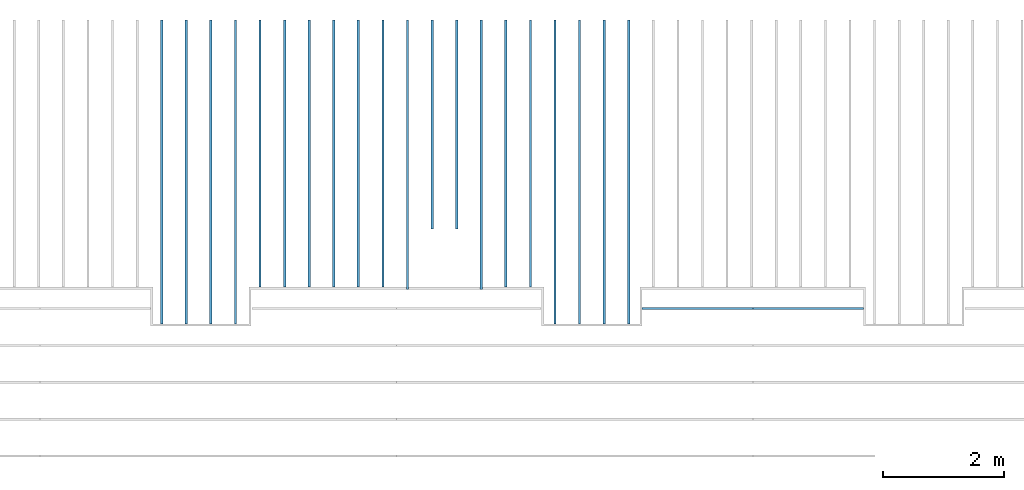
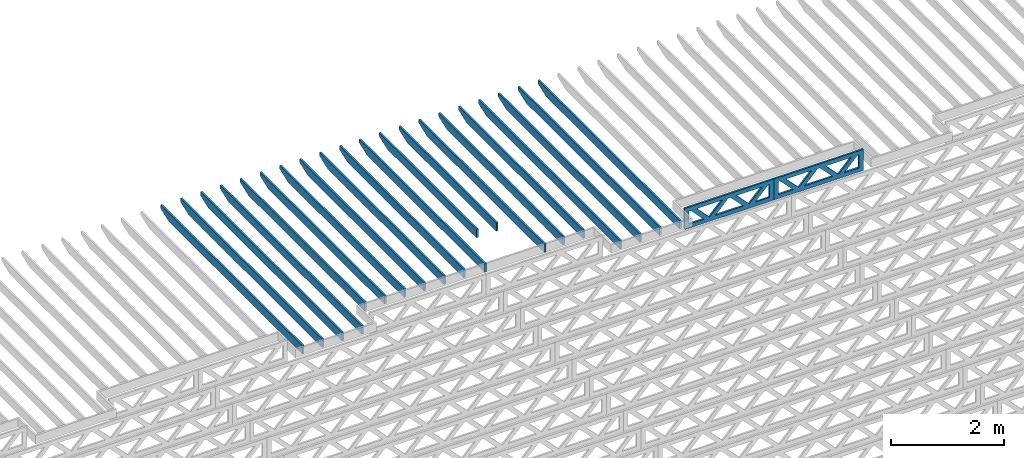
# One storey, part 9 of 17: 22 beams, 3 elements without a shape of their own.
"""IFC4 building model written with IfcOpenShell, lengths in feet."""

from ifc_helpers import new_model, entity, si_unit, converted_unit, derived_unit, direction, frame, frame_2d, origin, origin_2d_with_axis, place, context, subcontext, project, spatial, rectangle, extrude, clip, halfspace, source, transform, mapped, material, material_profile, profile_set, profile_usage, type_object, type_shapes, element, aggregate, save


model = new_model("IFC4")

# Units and contexts
model_context = context("Model", 3, precision=0.0001, world=origin(), true_north=direction((6.12303176911189e-17, 1.0)))
body_context = subcontext(model_context, "Body", "Model", "MODEL_VIEW")
ifc_project = project(units=[converted_unit("LENGTHUNIT", "FOOT", entity("IfcRatioMeasure", 0.3048), si_unit("LENGTHUNIT", "METRE"), dimensions=[1, 0, 0, 0, 0, 0, 0]), converted_unit("AREAUNIT", "SQUARE FOOT", entity("IfcRatioMeasure", 0.09290304), si_unit("AREAUNIT", "SQUARE_METRE"), dimensions=[2, 0, 0, 0, 0, 0, 0]), converted_unit("VOLUMEUNIT", "CUBIC FOOT", entity("IfcRatioMeasure", 0.028316846592), si_unit("VOLUMEUNIT", "CUBIC_METRE"), dimensions=[3, 0, 0, 0, 0, 0, 0]), converted_unit("PLANEANGLEUNIT", "DEGREE", entity("IfcRatioMeasure", 0.0174532925199433), si_unit("PLANEANGLEUNIT", "RADIAN"), dimensions=[0, 0, 0, 0, 0, 0, 0]), si_unit("MASSUNIT", "GRAM", prefix="KILO"), derived_unit("MASSDENSITYUNIT", [(si_unit("MASSUNIT", "GRAM", prefix="KILO"), 1), (si_unit("LENGTHUNIT", "METRE"), -3)]), derived_unit("MOMENTOFINERTIAUNIT", [(si_unit("LENGTHUNIT", "METRE"), 4)]), si_unit("TIMEUNIT", "SECOND"), si_unit("FREQUENCYUNIT", "HERTZ"), si_unit("THERMODYNAMICTEMPERATUREUNIT", "DEGREE_CELSIUS"), derived_unit("THERMALTRANSMITTANCEUNIT", [(si_unit("MASSUNIT", "GRAM", prefix="KILO"), 1), (si_unit("THERMODYNAMICTEMPERATUREUNIT", "KELVIN"), -1), (si_unit("TIMEUNIT", "SECOND"), -3)]), derived_unit("VOLUMETRICFLOWRATEUNIT", [(si_unit("LENGTHUNIT", "METRE"), 3), (si_unit("TIMEUNIT", "SECOND"), -1)]), si_unit("ELECTRICCURRENTUNIT", "AMPERE"), si_unit("ELECTRICVOLTAGEUNIT", "VOLT"), si_unit("POWERUNIT", "WATT"), si_unit("FORCEUNIT", "NEWTON"), si_unit("ILLUMINANCEUNIT", "LUX"), si_unit("LUMINOUSFLUXUNIT", "LUMEN"), si_unit("LUMINOUSINTENSITYUNIT", "CANDELA"), derived_unit("USERDEFINED", [(si_unit("MASSUNIT", "GRAM", prefix="KILO"), -1), (si_unit("LENGTHUNIT", "METRE"), -2), (si_unit("TIMEUNIT", "SECOND"), 3), (si_unit("LUMINOUSFLUXUNIT", "LUMEN"), 1)]), derived_unit("LINEARVELOCITYUNIT", [(si_unit("LENGTHUNIT", "METRE"), 1), (si_unit("TIMEUNIT", "SECOND"), -1)]), si_unit("PRESSUREUNIT", "PASCAL"), derived_unit("USERDEFINED", [(si_unit("LENGTHUNIT", "METRE"), -2), (si_unit("MASSUNIT", "GRAM", prefix="KILO"), 1), (si_unit("TIMEUNIT", "SECOND"), -2)]), derived_unit("LINEARFORCEUNIT", [(si_unit("MASSUNIT", "GRAM", prefix="KILO"), 1), (si_unit("LENGTHUNIT", "METRE"), 1), (si_unit("TIMEUNIT", "SECOND"), -2), (si_unit("LENGTHUNIT", "METRE"), -1)]), derived_unit("PLANARFORCEUNIT", [(si_unit("MASSUNIT", "GRAM", prefix="KILO"), 1), (si_unit("LENGTHUNIT", "METRE"), 1), (si_unit("TIMEUNIT", "SECOND"), -2), (si_unit("LENGTHUNIT", "METRE"), -2)])], contexts=[model_context])

# Site, building, storey
site_placement = place(None, origin())
site = spatial("IfcSite", under=ifc_project, at=site_placement, CompositionType="ELEMENT")
building_placement = place(site_placement, origin())
building = spatial("IfcBuilding", under=site, at=building_placement, CompositionType="ELEMENT")
storey_placement = place(building_placement, frame((0.0, 0.0, 30.4375000000082)))
storey = spatial("IfcBuildingStorey", under=building, at=storey_placement, Name="ROOF", CompositionType="ELEMENT", Elevation=30.4375000000082)

# Assembly, beam
assembly_1_placement = place(storey_placement, origin())
assembly_1 = element("IfcElementAssembly", 1, at=assembly_1_placement, inside=storey, Name="Structural Beam System:Structural Framing System", ObjectType="Structural Beam System:Structural Framing System", AssemblyPlace="NOTDEFINED", PredefinedType="BEAM_GRID")
ifc_material_1 = material(Name="WOOD TRUSS", Category="Materials")
ifc_material_profile_1 = material_profile(ifc_material_1, rectangle(XDim=1.73473973950632, YDim=0.125, at=origin_2d_with_axis()))
ifc_material_profile_2 = material_profile(ifc_material_1, rectangle(XDim=1.73473973950633, YDim=0.125, at=frame_2d((-1.11022302462516e-16, 0.0), x_axis=(1.0, 0.0))))
ifc_material_profile_3 = material_profile(ifc_material_1, rectangle(XDim=1.73473973950632, YDim=0.125, at=origin_2d_with_axis()))
ifc_material_profile_4 = material_profile(ifc_material_1, rectangle(XDim=1.73473973950633, YDim=0.125, at=origin_2d_with_axis()))
ifc_material_profile_5 = material_profile(ifc_material_1, rectangle(XDim=1.73473973950632, YDim=0.125, at=frame_2d((-5.55111512312578e-17, 0.0), x_axis=(1.0, 0.0))))
ifc_material_profile_6 = material_profile(ifc_material_1, rectangle(XDim=1.73473973950633, YDim=0.125, at=frame_2d((-2.77555756156289e-16, 0.0), x_axis=(1.0, 0.0))))
ifc_material_profile_7 = material_profile(ifc_material_1, rectangle(XDim=1.73473973950632, YDim=0.125, at=frame_2d((-4.9960036108132e-16, 0.0), x_axis=(1.0, 0.0))))
ifc_material_profile_8 = material_profile(ifc_material_1, rectangle(XDim=1.73473973950633, YDim=0.125, at=frame_2d((4.44089209850063e-16, 0.0), x_axis=(1.0, 0.0))))
ifc_material_profile_9 = material_profile(ifc_material_1, rectangle(XDim=1.73473973950632, YDim=0.125, at=origin_2d_with_axis()))
ifc_material_profile_10 = material_profile(ifc_material_1, rectangle(XDim=1.73473973950633, YDim=0.125, at=frame_2d((-4.9960036108132e-16, 0.0), x_axis=(1.0, 0.0))))
ifc_material_profile_11 = material_profile(ifc_material_1, rectangle(XDim=0.291666666666664, YDim=0.125, at=frame_2d((-2.77555756156289e-17, 0.0), x_axis=(1.0, 0.0))))
ifc_material_profile_12 = material_profile(ifc_material_1, rectangle(XDim=0.291666666666628, YDim=0.124999999999995, at=frame_2d((-5.55111512312578e-17, 0.0), x_axis=(1.0, 0.0))))
ifc_material_profile_13 = material_profile(ifc_material_1, rectangle(XDim=0.916666666666666, YDim=0.125000000000003, at=frame_2d((-2.77555756156289e-17, 0.0), x_axis=(1.0, 0.0))))
ifc_material_profile_14 = material_profile(ifc_material_1, rectangle(XDim=0.916666666666651, YDim=0.125, at=frame_2d((-2.77555756156289e-17, 0.0), x_axis=(1.0, 0.0))))
ifc_profile_set_1 = profile_set([ifc_material_profile_1, ifc_material_profile_2, ifc_material_profile_3, ifc_material_profile_4, ifc_material_profile_5, ifc_material_profile_6, ifc_material_profile_7, ifc_material_profile_8, ifc_material_profile_9, ifc_material_profile_10, ifc_material_profile_11, ifc_material_profile_12, ifc_material_profile_13, ifc_material_profile_14])
ifc_profile_usage_1 = profile_usage(ifc_profile_set_1, cardinal=8)
beam_type_1 = type_object("IfcBeamType", PredefinedType="BEAM", material=ifc_profile_set_1)
shared_shape_1 = source(origin(), body_context, "Body", "SweptSolid", [
    extrude(rectangle(XDim=1.73473973950632, YDim=0.125, at=frame_2d((5.55111512312578e-17, 0.0), x_axis=(1.0, 0.0))), frame((1.8533931188195, 0.0, 0.101118361020515), z_axis=(0.720569184836762, 0.0, -0.693383046997606), x_axis=(0.693383046997606, 0.0, 0.720569184836762)), (0.0, 0.0, 1.0), 0.291666666666667),
    extrude(rectangle(XDim=1.73473973950633, YDim=0.125, at=frame_2d((-1.11022302462516e-16, 0.0), x_axis=(1.0, 0.0))), frame((0.603107245146231, 0.0, -0.101118361020454), z_axis=(0.720569184836758, 0.0, 0.69338304699761), x_axis=(0.69338304699761, 0.0, -0.720569184836758)), (0.0, 0.0, 1.0), 0.291666666666667),
    extrude(rectangle(XDim=1.73473973950632, YDim=0.125, at=frame_2d((-5.55111512312578e-17, 0.0), x_axis=(1.0, 0.0))), frame((-0.81327325738963, 0.0, 0.101118361020554), z_axis=(0.720569184836762, 0.0, -0.693383046997606), x_axis=(0.693383046997606, 0.0, 0.720569184836762)), (0.0, 0.0, 1.0), 0.291666666666667),
    extrude(rectangle(XDim=1.73473973950633, YDim=0.125, at=frame_2d((-1.66533453693773e-16, 0.0), x_axis=(1.0, 0.0))), frame((-2.0635591310629, 0.0, -0.101118361020415), z_axis=(0.720569184836758, 0.0, 0.69338304699761), x_axis=(0.69338304699761, 0.0, -0.720569184836758)), (0.0, 0.0, 1.0), 0.291666666666666),
    extrude(rectangle(XDim=0.291666666666664, YDim=0.125, at=frame_2d((-2.77555756156289e-17, 0.0), x_axis=(1.0, 0.0))), frame((-2.99999985477115, 0.0, 0.604166666666611), z_axis=(1.0, 0.0, 0.0), x_axis=(0.0, 0.0, -1.0)), (0.0, 0.0, 1.0), 5.99999970954229),
    extrude(rectangle(XDim=0.291666666666628, YDim=0.124999999999995, at=frame_2d((-5.55111512312578e-17, 0.0), x_axis=(1.0, 0.0))), frame((-2.99999985477093, 0.0, -0.604166666666693), z_axis=(1.0, 0.0, 0.0), x_axis=(0.0, 0.0, -1.0)), (0.0, 0.0, 1.0), 5.99999970954208),
    extrude(rectangle(XDim=0.916666666666666, YDim=0.125000000000003, at=frame_2d((-2.77555756156289e-17, 0.0), x_axis=(1.0, 0.0))), frame((2.70833318810446, 0.0, 0.0), z_axis=(1.0, 0.0, 0.0), x_axis=(0.0, 0.0, -1.0)), (0.0, 0.0, 1.0), 0.291666666666687),
    extrude(rectangle(XDim=0.916666666666651, YDim=0.125, at=frame_2d((-2.77555756156289e-17, 0.0), x_axis=(1.0, 0.0))), frame((-2.99999985477115, 0.0, 0.0), z_axis=(1.0, 0.0, 0.0), x_axis=(0.0, 0.0, -1.0)), (0.0, 0.0, 1.0), 0.291666666666687),
])
type_shapes(beam_type_1, [shared_shape_1])
beam_1_placement = place(assembly_1_placement, frame((-180.738160630791, 957.861934882651, 0.749999999991608), z_axis=(0.0, 0.0, 1.0), x_axis=(-1.0, 0.0, 0.0)))
beam_1 = element("IfcBeam", 2, at=beam_1_placement, type_object=beam_type_1, material=ifc_profile_usage_1, PredefinedType="BEAM", context=body_context, shape_type="MappedRepresentation", body=[
    mapped(shared_shape_1, transform((0.0, 0.0, 0.0), scale=1.0)),
])
aggregate(assembly_1, [beam_1])

assembly_2_placement = place(storey_placement, origin())
assembly_2 = element("IfcElementAssembly", 3, at=assembly_2_placement, inside=storey, Name="Structural Beam System:Structural Framing System", ObjectType="Structural Beam System:Structural Framing System", AssemblyPlace="NOTDEFINED", PredefinedType="BEAM_GRID")
ifc_profile_usage_2 = profile_usage(ifc_profile_set_1, cardinal=8)
beam_type_2 = type_object("IfcBeamType", PredefinedType="BEAM", material=ifc_profile_set_1)
shared_shape_2 = source(origin(), body_context, "Body", "SweptSolid", [
    extrude(rectangle(XDim=1.73473973950632, YDim=0.125, at=frame_2d((5.55111512312578e-17, 0.0), x_axis=(1.0, 0.0))), frame((1.85339310373314, 0.0, 0.101118361020515), z_axis=(0.720569184836762, 0.0, -0.693383046997606), x_axis=(0.693383046997606, 0.0, 0.720569184836762)), (0.0, 0.0, 1.0), 0.291666666666667),
    extrude(rectangle(XDim=1.73473973950633, YDim=0.125, at=frame_2d((-1.11022302462516e-16, 0.0), x_axis=(1.0, 0.0))), frame((0.603107230059874, 0.0, -0.101118361020454), z_axis=(0.720569184836758, 0.0, 0.69338304699761), x_axis=(0.69338304699761, 0.0, -0.720569184836758)), (0.0, 0.0, 1.0), 0.291666666666667),
    extrude(rectangle(XDim=1.73473973950632, YDim=0.125, at=frame_2d((-5.55111512312578e-17, 0.0), x_axis=(1.0, 0.0))), frame((-0.813273242303273, 0.0, 0.101118361020554), z_axis=(0.720569184836762, 0.0, -0.693383046997606), x_axis=(0.693383046997606, 0.0, 0.720569184836762)), (0.0, 0.0, 1.0), 0.291666666666667),
    extrude(rectangle(XDim=1.73473973950633, YDim=0.125, at=frame_2d((-1.66533453693773e-16, 0.0), x_axis=(1.0, 0.0))), frame((-2.06355911597654, 0.0, -0.101118361020415), z_axis=(0.720569184836758, 0.0, 0.69338304699761), x_axis=(0.69338304699761, 0.0, -0.720569184836758)), (0.0, 0.0, 1.0), 0.291666666666666),
    extrude(rectangle(XDim=0.291666666666664, YDim=0.125, at=frame_2d((-2.77555756156289e-17, 0.0), x_axis=(1.0, 0.0))), frame((-2.99999983968479, 0.0, 0.604166666666611), z_axis=(1.0, 0.0, 0.0), x_axis=(0.0, 0.0, -1.0)), (0.0, 0.0, 1.0), 5.99999967936958),
    extrude(rectangle(XDim=0.291666666666628, YDim=0.124999999999995, at=frame_2d((-5.55111512312578e-17, 0.0), x_axis=(1.0, 0.0))), frame((-2.99999983968458, 0.0, -0.604166666666693), z_axis=(1.0, 0.0, 0.0), x_axis=(0.0, 0.0, -1.0)), (0.0, 0.0, 1.0), 5.99999967936937),
    extrude(rectangle(XDim=0.916666666666666, YDim=0.125000000000003, at=frame_2d((-2.77555756156289e-17, 0.0), x_axis=(1.0, 0.0))), frame((2.7083331730181, 0.0, 0.0), z_axis=(1.0, 0.0, 0.0), x_axis=(0.0, 0.0, -1.0)), (0.0, 0.0, 1.0), 0.291666666666687),
    extrude(rectangle(XDim=0.916666666666651, YDim=0.125, at=frame_2d((-2.77555756156289e-17, 0.0), x_axis=(1.0, 0.0))), frame((-2.99999983968479, 0.0, 0.0), z_axis=(1.0, 0.0, 0.0), x_axis=(0.0, 0.0, -1.0)), (0.0, 0.0, 1.0), 0.291666666666687),
])
type_shapes(beam_type_2, [shared_shape_2])
beam_2_placement = place(assembly_2_placement, frame((-186.738160325248, 957.861934882651, 0.749999999991601)))
beam_2 = element("IfcBeam", 4, at=beam_2_placement, type_object=beam_type_2, material=ifc_profile_usage_2, PredefinedType="BEAM", context=body_context, shape_type="MappedRepresentation", body=[
    mapped(shared_shape_2, transform((0.0, 0.0, 0.0), scale=1.0)),
])
aggregate(assembly_2, [beam_2])

# Assembly, beams
assembly_3_placement = place(storey_placement, origin())
assembly_3 = element("IfcElementAssembly", 5, at=assembly_3_placement, inside=storey, Name="Structural Beam System:Structural Framing System", ObjectType="Structural Beam System:Structural Framing System", AssemblyPlace="NOTDEFINED", PredefinedType="BEAM_GRID")
ifc_material_2 = material(Name="2X ROOF JOISTS - EXT. STAIN-1 - SEE LIFE SAFETY", Category="Materials")
ifc_material_profile_15 = material_profile(ifc_material_2, rectangle(XDim=0.604166666666667, YDim=0.125000000000011, at=frame_2d((0.0, 0.0), x_axis=(0.0, 1.0))))
ifc_profile_set_2 = profile_set([ifc_material_profile_15])
ifc_profile_usage_3 = profile_usage(ifc_profile_set_2, cardinal=8)
beam_type_3 = type_object("IfcBeamType", PredefinedType="BEAM", material=ifc_profile_set_2)
shared_shape_3 = source(origin(), body_context, "Body", "Clipping", [
    clip(extrude(rectangle(XDim=0.604166666666667, YDim=0.125000000000011, at=frame_2d((0.0, 0.0), x_axis=(0.0, 1.0))), frame((-8.24296473987818, 0.0, 0.0), z_axis=(1.0, 0.0, 0.0), x_axis=(0.0, 1.0, 0.0)), (0.0, 0.0, 1.0), 16.4859294797564), halfspace(frame((-7.26989982048795, -0.0625000000000026, -0.30208333333334), z_axis=(-0.34202014332567, 0.0, -0.939692620785908), x_axis=(0.0, 1.0, 0.0)), False)),
])
type_shapes(beam_type_3, [shared_shape_3])
beam_3_placement = place(assembly_3_placement, frame((-190.467327152128, 965.271566289195, 1.07291666665831), z_axis=(0.0, 0.0, 1.0), x_axis=(0.0, -1.0, 0.0)))
beam_3 = element("IfcBeam", 6, at=beam_3_placement, type_object=beam_type_3, material=ifc_profile_usage_3, PredefinedType="BEAM", context=body_context, shape_type="MappedRepresentation", body=[
    mapped(shared_shape_3, transform((0.0, 0.0, 0.0), scale=1.0)),
])
ifc_profile_usage_4 = profile_usage(ifc_profile_set_2, cardinal=8)
beam_4_placement = place(assembly_3_placement, frame((-191.800660485462, 965.271566289195, 1.07291666665831), z_axis=(0.0, 0.0, 1.0), x_axis=(0.0, -1.0, 0.0)))
beam_4 = element("IfcBeam", 7, at=beam_4_placement, type_object=beam_type_3, material=ifc_profile_usage_4, PredefinedType="BEAM", context=body_context, shape_type="MappedRepresentation", body=[
    mapped(shared_shape_3, transform((0.0, 0.0, 0.0), scale=1.0)),
])
ifc_profile_usage_5 = profile_usage(ifc_profile_set_2, cardinal=8)
beam_5_placement = place(assembly_3_placement, frame((-193.133993818795, 965.271566289195, 1.07291666665831), z_axis=(0.0, 0.0, 1.0), x_axis=(0.0, -1.0, 0.0)))
beam_5 = element("IfcBeam", 8, at=beam_5_placement, type_object=beam_type_3, material=ifc_profile_usage_5, PredefinedType="BEAM", context=body_context, shape_type="MappedRepresentation", body=[
    mapped(shared_shape_3, transform((0.0, 0.0, 0.0), scale=1.0)),
])
ifc_profile_usage_6 = profile_usage(ifc_profile_set_2, cardinal=8)
beam_6_placement = place(assembly_3_placement, frame((-194.467327152128, 965.271566289195, 1.07291666665831), z_axis=(0.0, 0.0, 1.0), x_axis=(0.0, -1.0, 0.0)))
beam_6 = element("IfcBeam", 9, at=beam_6_placement, type_object=beam_type_3, material=ifc_profile_usage_6, PredefinedType="BEAM", context=body_context, shape_type="MappedRepresentation", body=[
    mapped(shared_shape_3, transform((0.0, 0.0, 0.0), scale=1.0)),
])
ifc_profile_usage_7 = profile_usage(ifc_profile_set_2, cardinal=8)
beam_7_placement = place(assembly_3_placement, frame((-211.800660485462, 965.271566289195, 1.07291666665832), z_axis=(0.0, 0.0, 1.0), x_axis=(0.0, -1.0, 0.0)))
beam_7 = element("IfcBeam", 10, at=beam_7_placement, type_object=beam_type_3, material=ifc_profile_usage_7, PredefinedType="BEAM", context=body_context, shape_type="MappedRepresentation", body=[
    mapped(shared_shape_3, transform((0.0, 0.0, 0.0), scale=1.0)),
])
ifc_profile_usage_8 = profile_usage(ifc_profile_set_2, cardinal=8)
beam_8_placement = place(assembly_3_placement, frame((-213.133993818795, 965.271566289195, 1.07291666665832), z_axis=(0.0, 0.0, 1.0), x_axis=(0.0, -1.0, 0.0)))
beam_8 = element("IfcBeam", 11, at=beam_8_placement, type_object=beam_type_3, material=ifc_profile_usage_8, PredefinedType="BEAM", context=body_context, shape_type="MappedRepresentation", body=[
    mapped(shared_shape_3, transform((0.0, 0.0, 0.0), scale=1.0)),
])
ifc_profile_usage_9 = profile_usage(ifc_profile_set_2, cardinal=8)
beam_9_placement = place(assembly_3_placement, frame((-214.467327152128, 965.271566289195, 1.07291666665832), z_axis=(0.0, 0.0, 1.0), x_axis=(0.0, -1.0, 0.0)))
beam_9 = element("IfcBeam", 12, at=beam_9_placement, type_object=beam_type_3, material=ifc_profile_usage_9, PredefinedType="BEAM", context=body_context, shape_type="MappedRepresentation", body=[
    mapped(shared_shape_3, transform((0.0, 0.0, 0.0), scale=1.0)),
])
ifc_profile_usage_10 = profile_usage(ifc_profile_set_2, cardinal=8)
beam_10_placement = place(assembly_3_placement, frame((-215.800660485462, 965.271566289195, 1.07291666665832), z_axis=(0.0, 0.0, 1.0), x_axis=(0.0, -1.0, 0.0)))
beam_10 = element("IfcBeam", 13, at=beam_10_placement, type_object=beam_type_3, material=ifc_profile_usage_10, PredefinedType="BEAM", context=body_context, shape_type="MappedRepresentation", body=[
    mapped(shared_shape_3, transform((0.0, 0.0, 0.0), scale=1.0)),
])
ifc_profile_usage_11 = profile_usage(ifc_profile_set_2, cardinal=8)
beam_type_4 = type_object("IfcBeamType", PredefinedType="BEAM", material=ifc_profile_set_2)
shared_shape_4 = source(origin(), body_context, "Body", "Clipping", [
    clip(extrude(rectangle(XDim=0.604166666666667, YDim=0.125000000000011, at=frame_2d((0.0, 0.0), x_axis=(0.0, 1.0))), frame((-7.2429650122013, 0.0, 0.0), z_axis=(1.0, 0.0, 0.0), x_axis=(0.0, 1.0, 0.0)), (0.0, 0.0, 1.0), 14.4859300244026), halfspace(frame((-6.26990009281107, -0.0625000000000026, -0.30208333333334), z_axis=(-0.34202014332567, 0.0, -0.939692620785908), x_axis=(0.0, 1.0, 0.0)), False)),
])
type_shapes(beam_type_4, [shared_shape_4])
beam_11_placement = place(assembly_3_placement, frame((-195.800660485462, 966.271566016872, 1.07291666665831), z_axis=(0.0, 0.0, 1.0), x_axis=(0.0, -1.0, 0.0)))
beam_11 = element("IfcBeam", 14, at=beam_11_placement, type_object=beam_type_4, material=ifc_profile_usage_11, PredefinedType="BEAM", context=body_context, shape_type="MappedRepresentation", body=[
    mapped(shared_shape_4, transform((0.0, 0.0, 0.0), scale=1.0)),
])
ifc_profile_usage_12 = profile_usage(ifc_profile_set_2, cardinal=8)
beam_type_5 = type_object("IfcBeamType", PredefinedType="BEAM", material=ifc_profile_set_2)
shared_shape_5 = source(origin(), body_context, "Body", "Clipping", [
    clip(extrude(rectangle(XDim=0.604166666666667, YDim=0.125000000000011, at=frame_2d((0.0, 0.0), x_axis=(0.0, 1.0))), frame((-7.24296484470017, 0.0, 0.0), z_axis=(1.0, 0.0, 0.0), x_axis=(0.0, 1.0, 0.0)), (0.0, 0.0, 1.0), 14.4859296894003), halfspace(frame((-6.26989992530994, -0.0625000000000026, -0.30208333333334), z_axis=(-0.34202014332567, 0.0, -0.939692620785908), x_axis=(0.0, 1.0, 0.0)), False)),
])
type_shapes(beam_type_5, [shared_shape_5])
beam_12_placement = place(assembly_3_placement, frame((-197.133993818795, 966.271566184373, 1.07291666665831), z_axis=(0.0, 0.0, 1.0), x_axis=(0.0, -1.0, 0.0)))
beam_12 = element("IfcBeam", 15, at=beam_12_placement, type_object=beam_type_5, material=ifc_profile_usage_12, PredefinedType="BEAM", context=body_context, shape_type="MappedRepresentation", body=[
    mapped(shared_shape_5, transform((0.0, 0.0, 0.0), scale=1.0)),
])
ifc_profile_usage_13 = profile_usage(ifc_profile_set_2, cardinal=8)
beam_type_6 = type_object("IfcBeamType", PredefinedType="BEAM", material=ifc_profile_set_2)
shared_shape_6 = source(origin(), body_context, "Body", "Clipping", [
    clip(extrude(rectangle(XDim=0.604166666666667, YDim=0.125000000000011, at=frame_2d((0.0, -1.11022302462516e-16), x_axis=(0.0, 1.0))), frame((-7.24296467719904, 0.0, 0.0), z_axis=(1.0, 0.0, 0.0), x_axis=(0.0, 1.0, 0.0)), (0.0, 0.0, 1.0), 14.6109291868968), halfspace(frame((-6.26989975780881, -0.0625000000000026, -0.30208333333334), z_axis=(-0.34202014332567, 0.0, -0.939692620785908), x_axis=(0.0, 1.0, 0.0)), False)),
])
type_shapes(beam_type_6, [shared_shape_6])
beam_13_placement = place(assembly_3_placement, frame((-198.467327152128, 966.271566351874, 1.07291666665831), z_axis=(0.0, 0.0, 1.0), x_axis=(0.0, -1.0, 0.0)))
beam_13 = element("IfcBeam", 16, at=beam_13_placement, type_object=beam_type_6, material=ifc_profile_usage_13, PredefinedType="BEAM", context=body_context, shape_type="MappedRepresentation", body=[
    mapped(shared_shape_6, transform((0.0, 0.0, 0.0), scale=1.0)),
])
ifc_profile_usage_14 = profile_usage(ifc_profile_set_2, cardinal=8)
beam_type_7 = type_object("IfcBeamType", PredefinedType="BEAM", material=ifc_profile_set_2)
shared_shape_7 = source(origin(), body_context, "Body", "Clipping", [
    clip(extrude(rectangle(XDim=0.604166666666667, YDim=0.125000000000011, at=frame_2d((0.0, 0.0), x_axis=(0.0, 1.0))), frame((-5.78805380202516, 0.0, 0.0), z_axis=(1.0, 0.0, 0.0), x_axis=(0.0, 1.0, 0.0)), (0.0, 0.0, 1.0), 11.3399841963574), halfspace(frame((-4.81498888263493, -0.0625000000000026, -0.30208333333334), z_axis=(-0.34202014332567, 0.0, -0.939692620785908), x_axis=(0.0, 1.0, 0.0)), False)),
])
type_shapes(beam_type_7, [shared_shape_7])
beam_14_placement = place(assembly_3_placement, frame((-199.800660485462, 967.726477227048, 1.0729166666583), z_axis=(0.0, 0.0, 1.0), x_axis=(0.0, -1.0, 0.0)))
beam_14 = element("IfcBeam", 17, at=beam_14_placement, type_object=beam_type_7, material=ifc_profile_usage_14, PredefinedType="BEAM", context=body_context, shape_type="MappedRepresentation", body=[
    mapped(shared_shape_7, transform((0.0, 0.0, 0.0), scale=1.0)),
])
ifc_profile_usage_15 = profile_usage(ifc_profile_set_2, cardinal=8)
beam_15_placement = place(assembly_3_placement, frame((-201.133993818795, 967.726477227048, 1.07291666665831), z_axis=(0.0, 0.0, 1.0), x_axis=(0.0, -1.0, 0.0)))
beam_15 = element("IfcBeam", 18, at=beam_15_placement, type_object=beam_type_7, material=ifc_profile_usage_15, PredefinedType="BEAM", context=body_context, shape_type="MappedRepresentation", body=[
    mapped(shared_shape_7, transform((0.0, 0.0, 0.0), scale=1.0)),
])
ifc_profile_usage_16 = profile_usage(ifc_profile_set_2, cardinal=8)
beam_type_8 = type_object("IfcBeamType", PredefinedType="BEAM", material=ifc_profile_set_2)
shared_shape_8 = source(origin(), body_context, "Body", "Clipping", [
    clip(extrude(rectangle(XDim=0.604166666666667, YDim=0.125000000000011, at=frame_2d((0.0, -1.11022302462516e-16), x_axis=(0.0, 1.0))), frame((-7.2429641241003, 0.0, 0.0), z_axis=(1.0, 0.0, 0.0), x_axis=(0.0, 1.0, 0.0)), (0.0, 0.0, 1.0), 14.6109291868968), halfspace(frame((-6.26989920471007, -0.0625000000000026, -0.30208333333334), z_axis=(-0.34202014332567, 0.0, -0.939692620785908), x_axis=(0.0, 1.0, 0.0)), False)),
])
type_shapes(beam_type_8, [shared_shape_8])
beam_16_placement = place(assembly_3_placement, frame((-202.467327152128, 966.271566904973, 1.07291666665831), z_axis=(0.0, 0.0, 1.0), x_axis=(0.0, -1.0, 0.0)))
beam_16 = element("IfcBeam", 19, at=beam_16_placement, type_object=beam_type_8, material=ifc_profile_usage_16, PredefinedType="BEAM", context=body_context, shape_type="MappedRepresentation", body=[
    mapped(shared_shape_8, transform((0.0, 0.0, 0.0), scale=1.0)),
])
ifc_profile_usage_17 = profile_usage(ifc_profile_set_2, cardinal=8)
beam_type_9 = type_object("IfcBeamType", PredefinedType="BEAM", material=ifc_profile_set_2)
shared_shape_9 = source(origin(), body_context, "Body", "Clipping", [
    clip(extrude(rectangle(XDim=0.604166666666667, YDim=0.125000000000011, at=frame_2d((0.0, 0.0), x_axis=(0.0, 1.0))), frame((-7.2429639727896, 0.0, 0.0), z_axis=(1.0, 0.0, 0.0), x_axis=(0.0, 1.0, 0.0)), (0.0, 0.0, 1.0), 14.4859279455792), halfspace(frame((-6.26989905339937, -0.0625000000000026, -0.30208333333334), z_axis=(-0.34202014332567, 0.0, -0.939692620785908), x_axis=(0.0, 1.0, 0.0)), False)),
])
type_shapes(beam_type_9, [shared_shape_9])
beam_17_placement = place(assembly_3_placement, frame((-203.800660485462, 966.271567056284, 1.07291666665831), z_axis=(0.0, 0.0, 1.0), x_axis=(0.0, -1.0, 0.0)))
beam_17 = element("IfcBeam", 20, at=beam_17_placement, type_object=beam_type_9, material=ifc_profile_usage_17, PredefinedType="BEAM", context=body_context, shape_type="MappedRepresentation", body=[
    mapped(shared_shape_9, transform((0.0, 0.0, 0.0), scale=1.0)),
])
ifc_profile_usage_18 = profile_usage(ifc_profile_set_2, cardinal=8)
beam_type_10 = type_object("IfcBeamType", PredefinedType="BEAM", material=ifc_profile_set_2)
shared_shape_10 = source(origin(), body_context, "Body", "Clipping", [
    clip(extrude(rectangle(XDim=0.604166666666667, YDim=0.125000000000011, at=frame_2d((0.0, -1.11022302462516e-16), x_axis=(0.0, 1.0))), frame((-7.2429638214789, 0.0, 0.0), z_axis=(1.0, 0.0, 0.0), x_axis=(0.0, 1.0, 0.0)), (0.0, 0.0, 1.0), 14.4859276429578), halfspace(frame((-6.26989890208867, -0.0625000000000026, -0.30208333333334), z_axis=(-0.34202014332567, 0.0, -0.939692620785908), x_axis=(0.0, 1.0, 0.0)), False)),
])
type_shapes(beam_type_10, [shared_shape_10])
beam_18_placement = place(assembly_3_placement, frame((-205.133993818795, 966.271567207594, 1.07291666665831), z_axis=(0.0, 0.0, 1.0), x_axis=(0.0, -1.0, 0.0)))
beam_18 = element("IfcBeam", 21, at=beam_18_placement, type_object=beam_type_10, material=ifc_profile_usage_18, PredefinedType="BEAM", context=body_context, shape_type="MappedRepresentation", body=[
    mapped(shared_shape_10, transform((0.0, 0.0, 0.0), scale=1.0)),
])
ifc_profile_usage_19 = profile_usage(ifc_profile_set_2, cardinal=8)
beam_type_11 = type_object("IfcBeamType", PredefinedType="BEAM", material=ifc_profile_set_2)
shared_shape_11 = source(origin(), body_context, "Body", "Clipping", [
    clip(extrude(rectangle(XDim=0.604166666666667, YDim=0.125000000000011, at=frame_2d((0.0, 0.0), x_axis=(0.0, 1.0))), frame((-7.24296367016814, 0.0, 0.0), z_axis=(1.0, 0.0, 0.0), x_axis=(0.0, 1.0, 0.0)), (0.0, 0.0, 1.0), 14.4859273403363), halfspace(frame((-6.26989875077791, -0.0625000000000026, -0.30208333333334), z_axis=(-0.34202014332567, 0.0, -0.939692620785908), x_axis=(0.0, 1.0, 0.0)), False)),
])
type_shapes(beam_type_11, [shared_shape_11])
beam_19_placement = place(assembly_3_placement, frame((-206.467327152128, 966.271567358905, 1.07291666665831), z_axis=(0.0, 0.0, 1.0), x_axis=(0.0, -1.0, 0.0)))
beam_19 = element("IfcBeam", 22, at=beam_19_placement, type_object=beam_type_11, material=ifc_profile_usage_19, PredefinedType="BEAM", context=body_context, shape_type="MappedRepresentation", body=[
    mapped(shared_shape_11, transform((0.0, 0.0, 0.0), scale=1.0)),
])
ifc_profile_usage_20 = profile_usage(ifc_profile_set_2, cardinal=8)
beam_type_12 = type_object("IfcBeamType", PredefinedType="BEAM", material=ifc_profile_set_2)
shared_shape_12 = source(origin(), body_context, "Body", "Clipping", [
    clip(extrude(rectangle(XDim=0.604166666666667, YDim=0.125000000000011, at=frame_2d((0.0, 0.0), x_axis=(0.0, 1.0))), frame((-7.24296351885744, 0.0, 0.0), z_axis=(1.0, 0.0, 0.0), x_axis=(0.0, 1.0, 0.0)), (0.0, 0.0, 1.0), 14.4859270377149), halfspace(frame((-6.26989859946721, -0.0625000000000026, -0.30208333333334), z_axis=(-0.34202014332567, 0.0, -0.939692620785908), x_axis=(0.0, 1.0, 0.0)), False)),
])
type_shapes(beam_type_12, [shared_shape_12])
beam_20_placement = place(assembly_3_placement, frame((-207.800660485462, 966.271567510216, 1.07291666665832), z_axis=(0.0, 0.0, 1.0), x_axis=(0.0, -1.0, 0.0)))
beam_20 = element("IfcBeam", 23, at=beam_20_placement, type_object=beam_type_12, material=ifc_profile_usage_20, PredefinedType="BEAM", context=body_context, shape_type="MappedRepresentation", body=[
    mapped(shared_shape_12, transform((0.0, 0.0, 0.0), scale=1.0)),
])
ifc_profile_usage_21 = profile_usage(ifc_profile_set_2, cardinal=8)
beam_type_13 = type_object("IfcBeamType", PredefinedType="BEAM", material=ifc_profile_set_2)
shared_shape_13 = source(origin(), body_context, "Body", "Clipping", [
    clip(extrude(rectangle(XDim=0.604166666666667, YDim=0.125000000000011, at=frame_2d((0.0, 0.0), x_axis=(0.0, 1.0))), frame((-7.24296336754674, 0.0, 0.0), z_axis=(1.0, 0.0, 0.0), x_axis=(0.0, 1.0, 0.0)), (0.0, 0.0, 1.0), 14.4859267350935), halfspace(frame((-6.26989844815651, -0.0625000000000026, -0.30208333333334), z_axis=(-0.34202014332567, 0.0, -0.939692620785908), x_axis=(0.0, 1.0, 0.0)), False)),
])
type_shapes(beam_type_13, [shared_shape_13])
beam_21_placement = place(assembly_3_placement, frame((-209.133993818795, 966.271567661527, 1.07291666665832), z_axis=(0.0, 0.0, 1.0), x_axis=(0.0, -1.0, 0.0)))
beam_21 = element("IfcBeam", 24, at=beam_21_placement, type_object=beam_type_13, material=ifc_profile_usage_21, PredefinedType="BEAM", context=body_context, shape_type="MappedRepresentation", body=[
    mapped(shared_shape_13, transform((0.0, 0.0, 0.0), scale=1.0)),
])
ifc_profile_usage_22 = profile_usage(ifc_profile_set_2, cardinal=8)
beam_type_14 = type_object("IfcBeamType", PredefinedType="BEAM", material=ifc_profile_set_2)
shared_shape_14 = source(origin(), body_context, "Body", "Clipping", [
    clip(extrude(rectangle(XDim=0.604166666666667, YDim=0.125000000000011, at=frame_2d((0.0, 0.0), x_axis=(0.0, 1.0))), frame((-7.24296321623603, 0.0, 0.0), z_axis=(1.0, 0.0, 0.0), x_axis=(0.0, 1.0, 0.0)), (0.0, 0.0, 1.0), 14.4859264324721), halfspace(frame((-6.26989829684581, -0.0625000000000026, -0.30208333333334), z_axis=(-0.34202014332567, 0.0, -0.939692620785908), x_axis=(0.0, 1.0, 0.0)), False)),
])
type_shapes(beam_type_14, [shared_shape_14])
beam_22_placement = place(assembly_3_placement, frame((-210.467327152128, 966.271567812837, 1.07291666665832), z_axis=(0.0, 0.0, 1.0), x_axis=(0.0, -1.0, 0.0)))
beam_22 = element("IfcBeam", 25, at=beam_22_placement, type_object=beam_type_14, material=ifc_profile_usage_22, PredefinedType="BEAM", context=body_context, shape_type="MappedRepresentation", body=[
    mapped(shared_shape_14, transform((0.0, 0.0, 0.0), scale=1.0)),
])
aggregate(assembly_3, [beam_3, beam_4, beam_5, beam_6, beam_11, beam_12, beam_13, beam_14, beam_15, beam_16, beam_17, beam_18, beam_19, beam_20, beam_21, beam_22, beam_7, beam_8, beam_9, beam_10])

save(model, "model.ifc")
